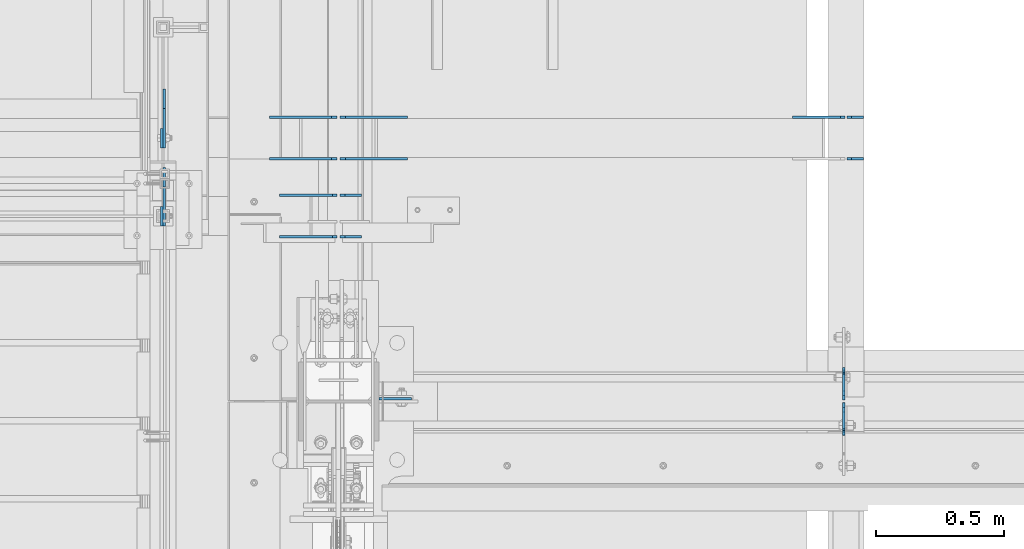
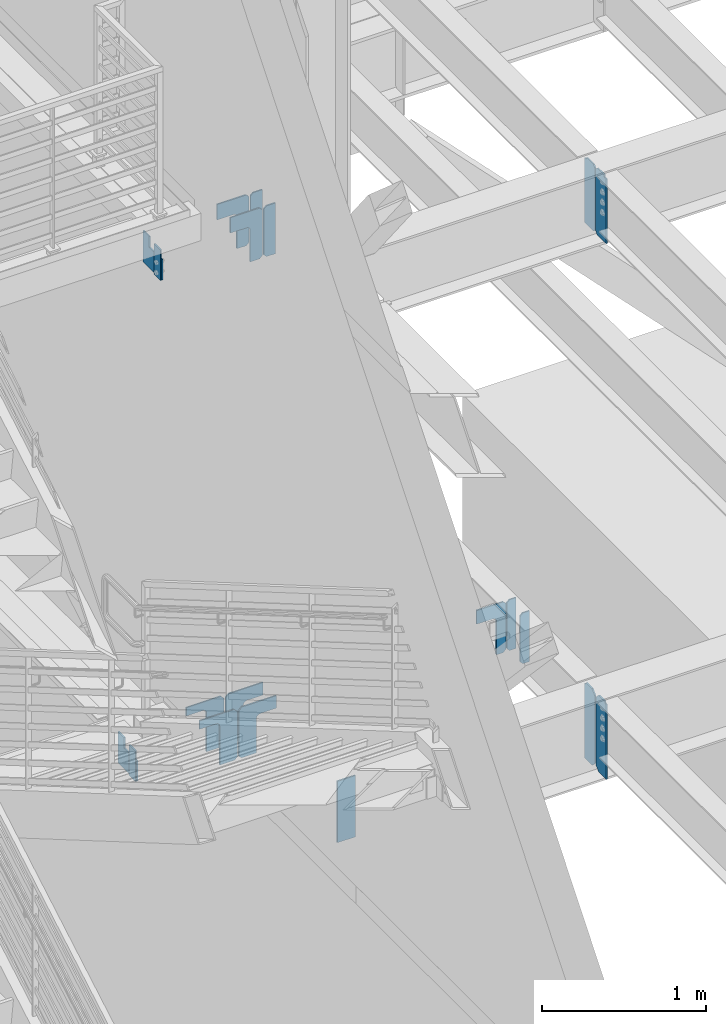
# One storey, part 1060 of 1179: 20 plates, 14 elements without a shape of their own.
"""IFC2X3 building model written with IfcOpenShell, lengths in millimetres."""

from ifc_helpers import new_model, si_unit, frame, origin_with_axes, place, context, subcontext, project, spatial, faceted_brep, material, type_object, element, aggregate, save


model = new_model("IFC2X3")

# Units and contexts
model_context = context("Model", 3, precision=1e-05, world=origin_with_axes())
body_context = subcontext(model_context, "Body", "Model", "MODEL_VIEW")
ifc_project = project(units=[si_unit("LENGTHUNIT", "METRE", prefix="MILLI"), si_unit("AREAUNIT", "SQUARE_METRE"), si_unit("VOLUMEUNIT", "CUBIC_METRE"), si_unit("MASSUNIT", "GRAM", prefix="KILO"), si_unit("TIMEUNIT", "SECOND"), si_unit("PLANEANGLEUNIT", "RADIAN"), si_unit("SOLIDANGLEUNIT", "STERADIAN"), si_unit("THERMODYNAMICTEMPERATUREUNIT", "DEGREE_CELSIUS"), si_unit("LUMINOUSINTENSITYUNIT", "LUMEN")], contexts=[model_context])

# Site, building, storey
site_placement = place(None, origin_with_axes())
site = spatial("IfcSite", under=ifc_project, at=site_placement, CompositionType="ELEMENT")
building_placement = place(site_placement, origin_with_axes())
building = spatial("IfcBuilding", under=site, at=building_placement, Name="Undefined", CompositionType="ELEMENT")
storey_placement = place(building_placement, origin_with_axes())
storey = spatial("IfcBuildingStorey", under=building, at=storey_placement, Name="Undefined", CompositionType="ELEMENT", Elevation=0.0)

# Assembly, plates
assembly_1_placement = place(storey_placement, origin_with_axes())
assembly_1 = element("IfcElementAssembly", 1, at=assembly_1_placement, inside=storey, Name="BEAM", AssemblyPlace="NOTDEFINED", PredefinedType="RIGID_FRAME")
ifc_material = material(Name="STEEL/A36")
plate_type_1 = type_object("IfcPlateType", PredefinedType="NOTDEFINED")
plate_1_placement = place(assembly_1_placement, frame((2405.06200008392, 34396.3625, 7497.7625), z_axis=(0.0, 0.0, 1.0), x_axis=(0.0, 1.0, 0.0)))
plate_1 = element("IfcPlate", 2, at=plate_1_placement, type_object=plate_type_1, material=ifc_material, Name="PLATE", context=body_context, shape_type="Brep", body=[
    faceted_brep([(100.012500000004, -4.76250000000073, 498.475), (100.012500000004, -4.76250000000073, 493.712499809265), (100.012500000004, 4.76250000000073, 493.712499809265), (100.012500000004, 4.76250000000073, 498.475), (100.979229922596, -4.76250000000073, 488.852420291219), (100.979229922596, 4.76250000000073, 488.852420291219), (103.732243823069, -4.76250000000073, 484.732243823066), (103.732243823069, 4.76250000000073, 484.732243823066), (107.852420291223, -4.76250000000073, 481.979229922587), (107.852420291223, 4.76250000000073, 481.979229922587), (112.71249980927, -4.76250000000073, 481.0125), (112.71249980927, 4.76250000000073, 481.0125), (127.000007629395, -4.76250000000073, 481.0125), (127.0, 4.76250000000073, 481.0125), (0.0, -4.76250000000073, 479.425006866455), (19.0499992370605, -4.76250000000073, 498.475006103516), (19.0499992370605, 4.76250000000073, 498.475006103516), (0.0, 4.76250000000073, 479.425006866455), (0.0, -4.76250000000073, 19.0499992370605), (0.0, 4.76250000000073, 19.0499992370605), (19.0499992370605, -4.76250000000073, 0.0), (19.0499992370605, 4.76250000000073, 0.0), (127.0, -4.76250000000073, 0.0), (127.0, 4.76250000000073, 0.0)], [[[0, 1, 2, 3]], [[4, 5, 2, 1]], [[6, 7, 5, 4]], [[8, 9, 7, 6]], [[10, 11, 9, 8]], [[12, 13, 11, 10]], [[14, 15, 16, 17]], [[18, 14, 17, 19]], [[20, 18, 19, 21]], [[22, 20, 21, 23]], [[8, 6, 4, 1, 0, 15, 14, 18, 20, 22, 12, 10]], [[16, 15, 0, 3]], [[23, 21, 19, 17, 16, 3, 2, 5, 7, 9, 11, 13]], [[22, 23, 13, 12]]]),
])
plate_2_placement = place(assembly_1_placement, frame((2405.06200008392, 34386.8375, 7497.7625), z_axis=(0.0, 0.0, 1.0), x_axis=(0.0, -1.0, 0.0)))
plate_2 = element("IfcPlate", 3, at=plate_2_placement, type_object=plate_type_1, material=ifc_material, Name="PLATE", context=body_context, shape_type="Brep", body=[
    faceted_brep([(100.012500000004, -4.76250000000073, 498.475), (100.012500000004, -4.76250000000073, 493.712499809265), (100.012500000004, 4.76250000000073, 493.712499809265), (100.012500000004, 4.76250000000073, 498.475), (100.979229922596, -4.76250000000073, 488.852420291219), (100.979229922596, 4.76250000000073, 488.852420291219), (103.732243823069, -4.76250000000073, 484.732243823066), (103.732243823069, 4.76250000000073, 484.732243823066), (107.852420291223, -4.76250000000073, 481.979229922587), (107.852420291223, 4.76250000000073, 481.979229922587), (112.71249980927, -4.76250000000073, 481.0125), (112.71249980927, 4.76250000000073, 481.0125), (127.000007629395, -4.76250000000073, 481.0125), (127.0, 4.76250000000073, 481.0125), (0.0, -4.76250000000073, 479.425006866455), (19.0499992370605, -4.76250000000073, 498.475006103516), (19.0499992370605, 4.76250000000073, 498.475006103516), (0.0, 4.76250000000073, 479.425006866455), (0.0, -4.76250000000073, 19.0499992370605), (0.0, 4.76250000000073, 19.0499992370605), (19.0499992370605, -4.76250000000073, 0.0), (19.0499992370605, 4.76250000000073, 0.0), (127.0, -4.76250000000073, 0.0), (127.0, 4.76250000000073, 0.0)], [[[0, 1, 2, 3]], [[4, 5, 2, 1]], [[6, 7, 5, 4]], [[8, 9, 7, 6]], [[10, 11, 9, 8]], [[12, 13, 11, 10]], [[14, 15, 16, 17]], [[18, 14, 17, 19]], [[20, 18, 19, 21]], [[22, 20, 21, 23]], [[8, 6, 4, 1, 0, 15, 14, 18, 20, 22, 12, 10]], [[16, 15, 0, 3]], [[23, 21, 19, 17, 16, 3, 2, 5, 7, 9, 11, 13]], [[22, 23, 13, 12]]]),
])
aggregate(assembly_1, [plate_1, plate_2])

# Assembly, plate
assembly_2_placement = place(storey_placement, origin_with_axes())
assembly_2 = element("IfcElementAssembly", 4, at=assembly_2_placement, inside=storey, Name="COLUMN", AssemblyPlace="NOTDEFINED", PredefinedType="RIGID_FRAME")
plate_3_placement = place(assembly_2_placement, frame((588.9625, 34401.91875, 4051.3), z_axis=(1.0, 0.0, 0.0), x_axis=(0.0, 0.0, -1.0)))
plate_3 = element("IfcPlate", 5, at=plate_3_placement, type_object=plate_type_1, material=ifc_material, Name="PLATE", context=body_context, shape_type="Brep", body=[
    faceted_brep([(0.0, -4.76249999999709, 0.0), (0.0, -4.76249999999709, 127.0), (0.0, 4.76249999999709, 127.0), (0.0, 4.76249999999709, 0.0), (457.200012207031, -4.76250000000073, 127.0), (457.200012207031, 4.76250000000073, 127.0), (457.200012207031, -4.76250000000073, 0.0), (457.200012207031, 4.76250000000073, 0.0)], [[[0, 1, 2, 3]], [[1, 4, 5, 2]], [[4, 6, 7, 5]], [[6, 0, 3, 7]], [[5, 7, 3, 2]], [[6, 4, 1, 0]]]),
])
aggregate(assembly_2, [plate_3])

# Assembly, plates
assembly_3_placement = place(storey_placement, origin_with_axes())
assembly_3 = element("IfcElementAssembly", 6, at=assembly_3_placement, inside=storey, Name="BEAM", AssemblyPlace="NOTDEFINED", PredefinedType="RIGID_FRAME")
plate_4_placement = place(assembly_3_placement, frame((2405.06173645238, 34386.04375, 3514.725), z_axis=(0.0, 0.0, 1.0), x_axis=(0.0, -1.0, 0.0)))
plate_4 = element("IfcPlate", 7, at=plate_4_placement, type_object=plate_type_1, material=ifc_material, Name="PLATE", context=body_context, shape_type="Brep", body=[
    faceted_brep([(108.743750000001, -4.76250000000073, 571.5), (108.743750000001, -4.76250000000073, 568.324999809266), (108.743750000001, 4.76250000000073, 568.324999809266), (108.743750000001, 4.76250000000073, 571.5), (109.710479922593, -4.76250000000073, 563.46492029122), (109.710479922593, 4.76250000000073, 563.46492029122), (112.463493823067, -4.76250000000073, 559.344743823066), (112.463493823067, 4.76250000000073, 559.344743823066), (116.58367029122, -4.76250000000073, 556.591729922588), (116.58367029122, 4.76250000000073, 556.591729922588), (121.443749809267, -4.76250000000073, 555.625), (121.443749809267, 4.76250000000073, 555.625), (127.000004116075, -4.76250000000073, 555.625), (127.000004116075, 4.76250000000073, 555.625), (0.0, -4.76250000000073, 536.575000762939), (34.9249992370605, -4.76250000000073, 571.5), (34.9249992370605, 4.76250000000073, 571.5), (0.0, 4.76250000000073, 536.575000762939), (0.0, -4.76250000000073, 34.9249999999993), (0.0, 4.76250000000073, 34.9249999999993), (34.9249992370715, -4.76249999996799, 0.0), (34.9249992370678, 4.76250000003347, 0.0), (127.0, -4.76250000000073, 0.0), (127.0, 4.76250000000073, 0.0)], [[[0, 1, 2, 3]], [[4, 5, 2, 1]], [[6, 7, 5, 4]], [[8, 9, 7, 6]], [[10, 11, 9, 8]], [[12, 13, 11, 10]], [[14, 15, 16, 17]], [[18, 14, 17, 19]], [[20, 18, 19, 21]], [[22, 20, 21, 23]], [[8, 6, 4, 1, 0, 15, 14, 18, 20, 22, 12, 10]], [[16, 15, 0, 3]], [[23, 21, 19, 17, 16, 3, 2, 5, 7, 9, 11, 13]], [[22, 23, 13, 12]]]),
])
plate_5_placement = place(assembly_3_placement, frame((2405.06176856843, 34397.156250119, 3514.725), z_axis=(0.0, 0.0, 1.0), x_axis=(0.0, 1.0, 0.0)))
plate_5 = element("IfcPlate", 8, at=plate_5_placement, type_object=plate_type_1, material=ifc_material, Name="PLATE", context=body_context, shape_type="Brep", body=[
    faceted_brep([(108.743750000001, -4.76250000000073, 571.5), (108.743750000001, -4.76250000000073, 568.324999809266), (108.743750000001, 4.76250000000073, 568.324999809266), (108.743750000001, 4.76250000000073, 571.5), (109.710479922593, -4.76250000000073, 563.46492029122), (109.710479922593, 4.76250000000073, 563.46492029122), (112.463493823067, -4.76250000000073, 559.344743823066), (112.463493823067, 4.76250000000073, 559.344743823066), (116.58367029122, -4.76250000000073, 556.591729922588), (116.58367029122, 4.76250000000073, 556.591729922588), (121.443749809267, -4.76250000000073, 555.625), (121.443749809267, 4.76250000000073, 555.625), (127.000004116075, -4.76250000000073, 555.625), (127.000004116075, 4.76250000000073, 555.625), (0.0, -4.76250000000073, 536.575000762939), (34.9249992370605, -4.76250000000073, 571.5), (34.9249992370605, 4.76250000000073, 571.5), (0.0, 4.76250000000073, 536.575000762939), (0.0, -4.76250000000073, 34.9249999999993), (0.0, 4.76250000000073, 34.9249999999993), (34.9249992370715, -4.76249999996799, 0.0), (34.9249992370678, 4.76250000003347, 0.0), (127.0, -4.76250000000073, 0.0), (127.0, 4.76250000000073, 0.0)], [[[0, 1, 2, 3]], [[4, 5, 2, 1]], [[6, 7, 5, 4]], [[8, 9, 7, 6]], [[10, 11, 9, 8]], [[12, 13, 11, 10]], [[14, 15, 16, 17]], [[18, 14, 17, 19]], [[20, 18, 19, 21]], [[22, 20, 21, 23]], [[8, 6, 4, 1, 0, 15, 14, 18, 20, 22, 12, 10]], [[16, 15, 0, 3]], [[23, 21, 19, 17, 16, 3, 2, 5, 7, 9, 11, 13]], [[22, 23, 13, 12]]]),
])
aggregate(assembly_3, [plate_4, plate_5])

# Assembly, plate
assembly_4_placement = place(storey_placement, origin_with_axes())
assembly_4 = element("IfcElementAssembly", 9, at=assembly_4_placement, inside=storey, Name="BEAM", AssemblyPlace="NOTDEFINED", PredefinedType="RIGID_FRAME")
plate_type_2 = type_object("IfcPlateType", PredefinedType="NOTDEFINED")
plate_6_placement = place(assembly_4_placement, frame((-249.237504637913, 35534.5998361718, 3981.45000000022), z_axis=(0.0, 0.0, -1.0), x_axis=(0.0, 1.0, 0.0)))
plate_6 = element("IfcPlate", 10, at=plate_6_placement, type_object=plate_type_2, material=ifc_material, Name="PLATE", context=body_context, shape_type="Brep", body=[
    faceted_brep([(0.0, -4.76249999999709, 0.0), (0.0, -4.76249999999999, 79.375000001397), (0.0, 4.76249999999999, 79.375000001397), (0.0, 4.76249999999709, 0.0), (-152.39983616901, -4.76249999999999, 79.375000001397), (-152.39983616901, 4.76249999999999, 79.375000001397), (-152.39983616901, -4.76249999999999, 231.775000001398), (-152.39983616901, 4.76249999999999, 231.775000001398), (76.2000000000044, -4.76249999999999, 231.775000001398), (76.2000000000044, 4.76249999999999, 231.775000001398), (76.1999999999971, -4.76249999999999, 0.0), (76.1999999999971, 4.76249999999999, 0.0)], [[[0, 1, 2, 3]], [[1, 4, 5, 2]], [[4, 6, 7, 5]], [[6, 8, 9, 7]], [[8, 10, 11, 9]], [[10, 0, 3, 11]], [[5, 7, 9, 11, 3, 2]], [[10, 8, 6, 4, 1, 0]]]),
])
aggregate(assembly_4, [plate_6])

assembly_5_placement = place(storey_placement, origin_with_axes())
assembly_5 = element("IfcElementAssembly", 11, at=assembly_5_placement, inside=storey, Name="BEAM", AssemblyPlace="NOTDEFINED", PredefinedType="RIGID_FRAME")
plate_7_placement = place(assembly_5_placement, frame((-249.237504637913, 35229.799836169, 7893.05), z_axis=(0.0, 0.0, -1.0), x_axis=(0.0, 1.0, 0.0)))
plate_7 = element("IfcPlate", 12, at=plate_7_placement, type_object=plate_type_2, material=ifc_material, Name="PLATE", context=body_context, shape_type="Brep", body=[
    faceted_brep([(0.0, -4.76249999999709, 0.0), (0.0, -4.76249999999999, 79.375000001397), (0.0, 4.76249999999999, 79.375000001397), (0.0, 4.76249999999709, 0.0), (-152.39983616901, -4.76249999999999, 79.375000001397), (-152.39983616901, 4.76249999999999, 79.375000001397), (-152.39983616901, -4.76249999999999, 231.775000001398), (-152.39983616901, 4.76249999999999, 231.775000001398), (76.2000000000044, -4.76249999999999, 231.775000001398), (76.2000000000044, 4.76249999999999, 231.775000001398), (76.1999999999971, -4.76249999999999, 0.0), (76.1999999999971, 4.76249999999999, 0.0)], [[[0, 1, 2, 3]], [[1, 4, 5, 2]], [[4, 6, 7, 5]], [[6, 8, 9, 7]], [[8, 10, 11, 9]], [[10, 0, 3, 11]], [[5, 7, 9, 11, 3, 2]], [[10, 8, 6, 4, 1, 0]]]),
])
aggregate(assembly_5, [plate_7])

assembly_6_placement = place(storey_placement, origin_with_axes())
assembly_6 = element("IfcElementAssembly", 13, at=assembly_6_placement, inside=storey, Name="BEAM", AssemblyPlace="NOTDEFINED", PredefinedType="RIGID_FRAME")
plate_type_3 = type_object("IfcPlateType", PredefinedType="NOTDEFINED")
plate_8_placement = place(assembly_6_placement, frame((-258.762504637913, 35382.2000000027, 3978.27499999882), z_axis=(0.0, 0.0, -1.0), x_axis=(0.0, 1.0, 0.0)))
plate_8 = element("IfcPlate", 14, at=plate_8_placement, type_object=plate_type_3, material=ifc_material, Name="PLATE", context=body_context, shape_type="Brep", body=[
    faceted_brep([(0.0, -4.76249999999709, 0.0), (0.0, -4.76249999999999, 228.6), (0.0, 4.76249999999999, 228.6), (0.0, 4.76249999999709, 0.0), (76.1999999999971, -4.76249999999999, 228.6), (76.1999999999971, 4.76249999999999, 228.6), (76.1999999999971, -4.76249999999999, 0.0), (76.1999999999971, 4.76249999999999, 0.0)], [[[0, 1, 2, 3]], [[1, 4, 5, 2]], [[4, 6, 7, 5]], [[6, 0, 3, 7]], [[5, 7, 3, 2]], [[6, 4, 1, 0]]]),
])
aggregate(assembly_6, [plate_8])

assembly_7_placement = place(storey_placement, origin_with_axes())
assembly_7 = element("IfcElementAssembly", 15, at=assembly_7_placement, inside=storey, Name="BEAM", AssemblyPlace="NOTDEFINED", PredefinedType="RIGID_FRAME")
plate_9_placement = place(assembly_7_placement, frame((-258.762504637913, 35077.4, 7889.8749999986), z_axis=(0.0, 0.0, -1.0), x_axis=(0.0, 1.0, 0.0)))
plate_9 = element("IfcPlate", 16, at=plate_9_placement, type_object=plate_type_3, material=ifc_material, Name="PLATE", context=body_context, shape_type="Brep", body=[
    faceted_brep([(0.0, -4.76249999999709, 0.0), (0.0, -4.76249999999999, 228.6), (0.0, 4.76249999999999, 228.6), (0.0, 4.76249999999709, 0.0), (76.1999999999971, -4.76249999999999, 228.6), (76.1999999999971, 4.76249999999999, 228.6), (76.1999999999971, -4.76249999999999, 0.0), (76.1999999999971, 4.76249999999999, 0.0)], [[[0, 1, 2, 3]], [[1, 4, 5, 2]], [[4, 6, 7, 5]], [[6, 0, 3, 7]], [[5, 7, 3, 2]], [[6, 4, 1, 0]]]),
])
aggregate(assembly_7, [plate_9])

# Assembly, plates
assembly_8_placement = place(storey_placement, origin_with_axes())
assembly_8 = element("IfcElementAssembly", 17, at=assembly_8_placement, inside=storey, Name="BEAM", AssemblyPlace="NOTDEFINED", PredefinedType="RIGID_FRAME")
plate_type_4 = type_object("IfcPlateType", PredefinedType="NOTDEFINED")
plate_10_placement = place(assembly_8_placement, frame((2481.26232982219, 35339.3374662643, 3711.575), z_axis=(0.0, 0.0, 1.0), x_axis=(-1.0, 0.0, 0.0)))
plate_10 = element("IfcPlate", 18, at=plate_10_placement, type_object=plate_type_4, material=ifc_material, Name="PLATE", context=body_context, shape_type="Brep", body=[
    faceted_brep([(0.0, -4.76249999999709, 0.0), (0.0, -4.76249999999709, 377.825012207031), (0.0, 4.76249999999709, 377.825012207031), (0.0, 4.76249999999709, 0.0), (46.0375022888184, -4.76249999999709, 377.825012207031), (46.0375022888184, 4.76249999999709, 377.825012207031), (65.0875015258789, -4.76249999999709, 358.775012969971), (65.0875015258789, 4.76249999999709, 358.775012969971), (65.0875015258789, -4.76249999999709, 19.0499992370605), (65.0875015258789, 4.76249999999709, 19.0499992370605), (46.0375022888184, -4.76249999999709, 0.0), (46.0375022888184, 4.76249999999709, 0.0)], [[[0, 1, 2, 3]], [[1, 4, 5, 2]], [[4, 6, 7, 5]], [[6, 8, 9, 7]], [[8, 10, 11, 9]], [[10, 0, 3, 11]], [[5, 7, 9, 11, 3, 2]], [[10, 8, 6, 4, 1, 0]]]),
])
plate_11_placement = place(assembly_8_placement, frame((2481.26232577406, 35501.2624662643, 3711.575), z_axis=(0.0, 0.0, 1.0), x_axis=(-1.0, 0.0, 0.0)))
plate_11 = element("IfcPlate", 19, at=plate_11_placement, type_object=plate_type_4, material=ifc_material, Name="PLATE", context=body_context, shape_type="Brep", body=[
    faceted_brep([(0.0, -4.76249999999709, 0.0), (0.0, -4.76249999999709, 377.825012207031), (0.0, 4.76249999999709, 377.825012207031), (0.0, 4.76249999999709, 0.0), (46.0375022888184, -4.76249999999709, 377.825012207031), (46.0375022888184, 4.76249999999709, 377.825012207031), (65.0875015258789, -4.76249999999709, 358.775012969971), (65.0875015258789, 4.76249999999709, 358.775012969971), (65.0875015258789, -4.76249999999709, 19.0499992370605), (65.0875015258789, 4.76249999999709, 19.0499992370605), (46.0375022888184, -4.76249999999709, 0.0), (46.0375022888184, 4.76249999999709, 0.0)], [[[0, 1, 2, 3]], [[1, 4, 5, 2]], [[4, 6, 7, 5]], [[6, 8, 9, 7]], [[8, 10, 11, 9]], [[10, 0, 3, 11]], [[5, 7, 9, 11, 3, 2]], [[10, 8, 6, 4, 1, 0]]]),
])
aggregate(assembly_8, [plate_10, plate_11])

# Assembly, plate
assembly_9_placement = place(storey_placement, origin_with_axes())
assembly_9 = element("IfcElementAssembly", 20, at=assembly_9_placement, inside=storey, Name="BEAM", AssemblyPlace="NOTDEFINED", PredefinedType="RIGID_FRAME")
plate_type_5 = type_object("IfcPlateType", PredefinedType="NOTDEFINED")
plate_12_placement = place(assembly_9_placement, frame((426.291860782879, 35034.5375199548, 7994.65), z_axis=(-1.0, 0.0, 0.0), x_axis=(0.0, 0.0, -1.0)))
plate_12 = element("IfcPlate", 21, at=plate_12_placement, type_object=plate_type_5, material=ifc_material, Name="PLATE", context=body_context, shape_type="Brep", body=[
    faceted_brep([(0.0, -4.76250000000073, 19.0499992370605), (5.15311512572225e-07, -4.76250000051368, 224.679358085698), (5.15311512572225e-07, 4.7624999994805, 224.679358085698), (0.0, 4.76250000000073, 19.0499992370605), (114.300000000001, -4.76249999952415, 224.679310452431), (114.300000000001, 4.7625000004773, 224.679310452431), (114.300000000001, -4.76249999977153, 110.331249618541), (114.300000000001, 4.76250000022992, 110.331249618541), (116.233459845177, -4.76249999979336, 100.61109058245), (116.233459845177, 4.76250000020082, 100.61109058245), (121.739487646133, -4.76249999981519, 92.3707376461425), (121.739487646133, 4.76250000018626, 92.3707376461423), (129.97984058244, -4.76249999982247, 86.8647098451864), (129.97984058244, 4.76250000017899, 86.8647098451863), (139.699999618531, -4.76249999982974, 84.9312500000107), (139.699999618531, 4.76250000017171, 84.9312500000105), (377.825000000001, -4.76249999982974, 84.9312500000098), (377.825000000001, 4.76250000017171, 84.9312500000096), (377.825000000001, -4.76250000004802, 19.0499992370604), (377.825000000001, 4.76249999995343, 19.0499992370605), (358.77500076294, -4.76249999999709, -5.6843418860808e-14), (358.77500076294, 4.76249999999709, 0.0), (19.0499992370605, -4.76250000000073, 0.0), (19.0499992370605, 4.76250000000073, 0.0)], [[[0, 1, 2, 3]], [[1, 4, 5, 2]], [[4, 6, 7, 5]], [[6, 8, 9, 7]], [[8, 10, 11, 9]], [[10, 12, 13, 11]], [[12, 14, 15, 13]], [[14, 16, 17, 15]], [[16, 18, 19, 17]], [[18, 20, 21, 19]], [[20, 22, 23, 21]], [[22, 0, 3, 23]], [[5, 7, 9, 11, 13, 15, 17, 19, 21, 23, 3, 2]], [[22, 20, 18, 16, 14, 12, 10, 8, 6, 4, 1, 0]]]),
])

assembly_10_placement = place(storey_placement, origin_with_axes())
assembly_10 = element("IfcElementAssembly", 22, at=assembly_10_placement, inside=storey, Name="PLATE", AssemblyPlace="NOTDEFINED", PredefinedType="RIGID_FRAME")
plate_13_placement = place(assembly_10_placement, frame((426.291856734725, 35196.462521345, 7994.65), z_axis=(-1.0, 0.0, 0.0), x_axis=(0.0, 0.0, -1.0)))
plate_13 = element("IfcPlate", 23, at=plate_13_placement, type_object=plate_type_5, material=ifc_material, Name="PLATE", context=body_context, shape_type="Brep", body=[
    faceted_brep([(0.0, -4.76250000000073, 19.0499992370605), (5.15311512572225e-07, -4.76250000051368, 224.679358085698), (5.15311512572225e-07, 4.7624999994805, 224.679358085698), (0.0, 4.76250000000073, 19.0499992370605), (114.300000000001, -4.76249999952415, 224.679310452431), (114.300000000001, 4.7625000004773, 224.679310452431), (114.300000000001, -4.76249999977153, 110.331249618541), (114.300000000001, 4.76250000022992, 110.331249618541), (116.233459845177, -4.76249999979336, 100.61109058245), (116.233459845177, 4.76250000020082, 100.61109058245), (121.739487646133, -4.76249999981519, 92.3707376461425), (121.739487646133, 4.76250000018626, 92.3707376461423), (129.97984058244, -4.76249999982247, 86.8647098451864), (129.97984058244, 4.76250000017899, 86.8647098451863), (139.699999618531, -4.76249999982974, 84.9312500000107), (139.699999618531, 4.76250000017171, 84.9312500000105), (377.825000000001, -4.76249999982974, 84.9312500000098), (377.825000000001, 4.76250000017171, 84.9312500000096), (377.825000000001, -4.76250000004802, 19.0499992370604), (377.825000000001, 4.76249999995343, 19.0499992370605), (358.77500076294, -4.76249999999709, -5.6843418860808e-14), (358.77500076294, 4.76249999999709, 0.0), (19.0499992370605, -4.76250000000073, 0.0), (19.0499992370605, 4.76250000000073, 0.0)], [[[0, 1, 2, 3]], [[1, 4, 5, 2]], [[4, 6, 7, 5]], [[6, 8, 9, 7]], [[8, 10, 11, 9]], [[10, 12, 13, 11]], [[12, 14, 15, 13]], [[14, 16, 17, 15]], [[16, 18, 19, 17]], [[18, 20, 21, 19]], [[20, 22, 23, 21]], [[22, 0, 3, 23]], [[5, 7, 9, 11, 13, 15, 17, 19, 21, 23, 3, 2]], [[22, 20, 18, 16, 14, 12, 10, 8, 6, 4, 1, 0]]]),
])
aggregate(assembly_10, [plate_13])

assembly_11_placement = place(storey_placement, origin_with_axes())
assembly_11 = element("IfcElementAssembly", 24, at=assembly_11_placement, inside=storey, Name="PLATE", AssemblyPlace="NOTDEFINED", PredefinedType="RIGID_FRAME")
plate_type_6 = type_object("IfcPlateType", PredefinedType="NOTDEFINED")
plate_14_placement = place(assembly_11_placement, frame((2409.82471255166, 35501.2624673052, 4089.4), z_axis=(-1.0, 0.0, 0.0), x_axis=(0.0, 0.0, -1.0)))
plate_14 = element("IfcPlate", 25, at=plate_14_placement, type_object=plate_type_6, material=ifc_material, Name="PLATE", context=body_context, shape_type="Brep", body=[
    faceted_brep([(0.0, -4.76250000000073, 19.0499992370605), (-8.85103781911312e-06, -4.76249999937863, 206.374999999996), (-8.85103781911312e-06, 4.76250000062282, 206.374999999998), (0.0, 4.76250000000073, 19.0499992370605), (101.599991149047, -4.76249999937863, 206.374988153153), (101.599991149047, 4.76250000062282, 206.374988153154), (101.6, -4.76249999970605, 92.0266613006611), (101.6, 4.7625000002954, 92.0266613006606), (103.533459845175, -4.76249999973516, 82.3065022645701), (103.533459845175, 4.7625000002663, 82.3065022645692), (109.039487646132, -4.76249999976426, 74.0661493282628), (109.039487646132, 4.7625000002372, 74.0661493282619), (117.279840582439, -4.76249999977881, 68.5601215273068), (117.279840582439, 4.76250000022264, 68.5601215273059), (126.99999961853, -4.76249999978609, 66.6266616821308), (126.99999961853, 4.76250000021537, 66.6266616821304), (377.825, -4.76249999978609, 66.6266616821308), (377.825, 4.76250000021537, 66.6266616821304), (377.825000000001, -4.76250000004802, 19.0499992370604), (377.825000000001, 4.76249999995343, 19.0499992370605), (358.77500076294, -4.76249999999709, -5.6843418860808e-14), (358.77500076294, 4.76249999999709, 0.0), (19.0499992370605, -4.76250000000073, 0.0), (19.0499992370605, 4.76250000000073, 0.0)], [[[0, 1, 2, 3]], [[1, 4, 5, 2]], [[4, 6, 7, 5]], [[6, 8, 9, 7]], [[8, 10, 11, 9]], [[10, 12, 13, 11]], [[12, 14, 15, 13]], [[14, 16, 17, 15]], [[16, 18, 19, 17]], [[18, 20, 21, 19]], [[20, 22, 23, 21]], [[22, 0, 3, 23]], [[5, 7, 9, 11, 13, 15, 17, 19, 21, 23, 3, 2]], [[22, 20, 18, 16, 14, 12, 10, 8, 6, 4, 1, 0]]]),
])
aggregate(assembly_11, [plate_14])

# Plate
plate_type_7 = type_object("IfcPlateType", PredefinedType="NOTDEFINED")
plate_15_placement = place(assembly_9_placement, frame((520.700000000001, 35034.5375157507, 7616.825), z_axis=(0.0, 0.0, 1.0), x_axis=(-1.0, 0.0, 0.0)))
plate_15 = element("IfcPlate", 26, at=plate_15_placement, type_object=plate_type_7, material=ifc_material, Name="PLATE", context=body_context, shape_type="Brep", body=[
    faceted_brep([(0.0, -4.76249999999709, 0.0), (0.0, -4.76249999999709, 377.825012207031), (0.0, 4.76249999999709, 377.825012207031), (0.0, 4.76249999999709, 0.0), (64.2937507629395, -4.76249999999709, 377.825012207031), (64.2937507629395, 4.76249999999709, 377.825012207031), (83.34375, -4.76249999999709, 358.775012969971), (83.34375, 4.76249999999709, 358.775012969971), (83.34375, -4.76249999999709, 19.0499992370605), (83.34375, 4.76249999999709, 19.0499992370605), (64.2937507629395, -4.76249999999709, 0.0), (64.2937507629395, 4.76249999999709, 0.0)], [[[0, 1, 2, 3]], [[1, 4, 5, 2]], [[4, 6, 7, 5]], [[6, 8, 9, 7]], [[8, 10, 11, 9]], [[10, 0, 3, 11]], [[5, 7, 9, 11, 3, 2]], [[10, 8, 6, 4, 1, 0]]]),
])

plate_16_placement = place(assembly_9_placement, frame((520.700000000001, 35196.4625157507, 7616.825), z_axis=(0.0, 0.0, 1.0), x_axis=(-1.0, 0.0, 0.0)))
plate_16 = element("IfcPlate", 27, at=plate_16_placement, type_object=plate_type_7, material=ifc_material, Name="PLATE", context=body_context, shape_type="Brep", body=[
    faceted_brep([(0.0, -4.76249999999709, 0.0), (0.0, -4.76249999999709, 377.825012207031), (0.0, 4.76249999999709, 377.825012207031), (0.0, 4.76249999999709, 0.0), (64.2937507629395, -4.76249999999709, 377.825012207031), (64.2937507629395, 4.76249999999709, 377.825012207031), (83.34375, -4.76249999999709, 358.775012969971), (83.34375, 4.76249999999709, 358.775012969971), (83.34375, -4.76249999999709, 19.0499992370605), (83.34375, 4.76249999999709, 19.0499992370605), (64.2937507629395, -4.76249999999709, 0.0), (64.2937507629395, 4.76249999999709, 0.0)], [[[0, 1, 2, 3]], [[1, 4, 5, 2]], [[4, 6, 7, 5]], [[6, 8, 9, 7]], [[8, 10, 11, 9]], [[10, 0, 3, 11]], [[5, 7, 9, 11, 3, 2]], [[10, 8, 6, 4, 1, 0]]]),
])

aggregate(assembly_9, [plate_15, plate_16, plate_12])

# Assembly, plate
assembly_12_placement = place(storey_placement, origin_with_axes())
assembly_12 = element("IfcElementAssembly", 28, at=assembly_12_placement, inside=storey, Name="BEAM", AssemblyPlace="NOTDEFINED", PredefinedType="RIGID_FRAME")
plate_type_8 = type_object("IfcPlateType", PredefinedType="NOTDEFINED")
plate_17_placement = place(assembly_12_placement, frame((426.291860782883, 35339.3375042069, 4081.4625), z_axis=(-1.0, 0.0, 0.0), x_axis=(0.0, 0.0, -1.0)))
plate_17 = element("IfcPlate", 29, at=plate_17_placement, type_object=plate_type_8, material=ifc_material, Name="PLATE", context=body_context, shape_type="Brep", body=[
    faceted_brep([(0.0, -4.76250000000073, 22.2250003814697), (0.0, -4.76250000047003, 264.318756103518), (0.0, 4.76249999953143, 264.318756103518), (0.0, 4.76250000000073, 22.2250003814697), (61.9124999999999, -4.76250000047003, 264.318756103518), (61.9124999999999, 4.76249999953143, 264.318756103518), (61.9124999999999, -4.76250000025902, 148.431249618531), (61.9124999999999, 4.76249999973516, 148.431249618531), (63.8459598451755, -4.76250000024447, 138.71109058244), (63.8459598451755, 4.76249999975698, 138.71109058244), (69.3519876461319, -4.76250000022992, 130.470737646133), (69.3519876461319, 4.76249999977153, 130.470737646133), (77.5923405824392, -4.76250000022264, 124.964709845177), (77.5923405824392, 4.76249999977881, 124.964709845177), (87.3124996185302, -4.76250000021537, 123.031250000001), (87.3124996185302, 4.76249999977881, 123.031250000001), (377.825, -4.76250000021537, 123.031250000001), (377.825, 4.76249999977881, 123.031250000001), (377.825000000001, -4.76250000004802, 19.0499992370604), (377.825000000001, 4.76249999995343, 19.0499992370605), (358.77500076294, -4.76249999999709, -5.6843418860808e-14), (358.77500076294, 4.76249999999709, 0.0), (22.2250003814697, -4.76250000000073, 0.0), (22.2250003814697, 4.76250000000073, 0.0)], [[[0, 1, 2, 3]], [[1, 4, 5, 2]], [[4, 6, 7, 5]], [[6, 8, 9, 7]], [[8, 10, 11, 9]], [[10, 12, 13, 11]], [[12, 14, 15, 13]], [[14, 16, 17, 15]], [[16, 18, 19, 17]], [[18, 20, 21, 19]], [[20, 22, 23, 21]], [[22, 0, 3, 23]], [[5, 7, 9, 11, 13, 15, 17, 19, 21, 23, 3, 2]], [[22, 20, 18, 16, 14, 12, 10, 8, 6, 4, 1, 0]]]),
])

assembly_13_placement = place(storey_placement, origin_with_axes())
assembly_13 = element("IfcElementAssembly", 30, at=assembly_13_placement, inside=storey, Name="PLATE", AssemblyPlace="NOTDEFINED", PredefinedType="RIGID_FRAME")
plate_18_placement = place(assembly_13_placement, frame((426.291856734724, 35501.2625055971, 4081.4625), z_axis=(-1.0, 0.0, 0.0), x_axis=(0.0, 0.0, -1.0)))
plate_18 = element("IfcPlate", 31, at=plate_18_placement, type_object=plate_type_8, material=ifc_material, Name="PLATE", context=body_context, shape_type="Brep", body=[
    faceted_brep([(0.0, -4.76250000000073, 22.2250003814697), (0.0, -4.76250000047003, 264.318756103518), (0.0, 4.76249999953143, 264.318756103518), (0.0, 4.76250000000073, 22.2250003814697), (61.9124999999999, -4.76250000047003, 264.318756103518), (61.9124999999999, 4.76249999953143, 264.318756103518), (61.9124999999999, -4.76250000025902, 148.431249618531), (61.9124999999999, 4.76249999973516, 148.431249618531), (63.8459598451755, -4.76250000024447, 138.71109058244), (63.8459598451755, 4.76249999975698, 138.71109058244), (69.3519876461319, -4.76250000022992, 130.470737646133), (69.3519876461319, 4.76249999977153, 130.470737646133), (77.5923405824392, -4.76250000022264, 124.964709845177), (77.5923405824392, 4.76249999977881, 124.964709845177), (87.3124996185302, -4.76250000021537, 123.031250000001), (87.3124996185302, 4.76249999977881, 123.031250000001), (377.825, -4.76250000021537, 123.031250000001), (377.825, 4.76249999977881, 123.031250000001), (377.825000000001, -4.76250000004802, 19.0499992370604), (377.825000000001, 4.76249999995343, 19.0499992370605), (358.77500076294, -4.76249999999709, -5.6843418860808e-14), (358.77500076294, 4.76249999999709, 0.0), (22.2250003814697, -4.76250000000073, 0.0), (22.2250003814697, 4.76250000000073, 0.0)], [[[0, 1, 2, 3]], [[1, 4, 5, 2]], [[4, 6, 7, 5]], [[6, 8, 9, 7]], [[8, 10, 11, 9]], [[10, 12, 13, 11]], [[12, 14, 15, 13]], [[14, 16, 17, 15]], [[16, 18, 19, 17]], [[18, 20, 21, 19]], [[20, 22, 23, 21]], [[22, 0, 3, 23]], [[5, 7, 9, 11, 13, 15, 17, 19, 21, 23, 3, 2]], [[22, 20, 18, 16, 14, 12, 10, 8, 6, 4, 1, 0]]]),
])
aggregate(assembly_13, [plate_18])

assembly_14_placement = place(storey_placement, origin_with_axes())
assembly_14 = element("IfcElementAssembly", 32, at=assembly_14_placement, inside=storey, Name="PLATE", AssemblyPlace="NOTDEFINED", PredefinedType="RIGID_FRAME")
plate_19_placement = place(assembly_14_placement, frame((437.356108916965, 35501.2624946544, 4081.4625), z_axis=(1.0, 0.0, 0.0), x_axis=(0.0, 0.0, -1.0)))
plate_19 = element("IfcPlate", 33, at=plate_19_placement, type_object=plate_type_8, material=ifc_material, Name="PLATE", context=body_context, shape_type="Brep", body=[
    faceted_brep([(0.0, -4.76250000000073, 22.2250003814697), (0.0, -4.76250000047003, 264.318756103518), (0.0, 4.76249999953143, 264.318756103518), (0.0, 4.76250000000073, 22.2250003814697), (93.6624999999999, -4.76249999943684, 264.318756103516), (93.6624999999999, 4.76250000056461, 264.318756103516), (93.6624999999999, -4.76249999967695, 150.01874961853), (93.6624999999999, 4.76250000032451, 150.01874961853), (95.5959598451755, -4.76249999969878, 140.298590582439), (95.5959598451755, 4.76250000030268, 140.298590582439), (101.101987646132, -4.76249999971333, 132.058237646132), (101.101987646132, 4.76250000028085, 132.058237646132), (109.342340582439, -4.76249999972788, 126.552209845176), (109.342340582439, 4.76250000027358, 126.552209845176), (119.06249961853, -4.76249999973516, 124.61875), (119.06249961853, 4.7625000002663, 124.61875), (377.825, -4.76249999973516, 124.61875), (377.825, 4.7625000002663, 124.61875), (377.825000000001, -4.76250000004802, 19.0499992370604), (377.825000000001, 4.76249999995343, 19.0499992370605), (358.77500076294, -4.76249999999709, -5.6843418860808e-14), (358.77500076294, 4.76249999999709, 0.0), (22.2250003814697, -4.76250000000073, 0.0), (22.2250003814697, 4.76250000000073, 0.0)], [[[0, 1, 2, 3]], [[1, 4, 5, 2]], [[4, 6, 7, 5]], [[6, 8, 9, 7]], [[8, 10, 11, 9]], [[10, 12, 13, 11]], [[12, 14, 15, 13]], [[14, 16, 17, 15]], [[16, 18, 19, 17]], [[18, 20, 21, 19]], [[20, 22, 23, 21]], [[22, 0, 3, 23]], [[5, 7, 9, 11, 13, 15, 17, 19, 21, 23, 3, 2]], [[22, 20, 18, 16, 14, 12, 10, 8, 6, 4, 1, 0]]]),
])
aggregate(assembly_14, [plate_19])

# Plate
plate_20_placement = place(assembly_12_placement, frame((437.356112965123, 35339.3374932642, 4081.4625), z_axis=(1.0, 0.0, 0.0), x_axis=(0.0, 0.0, -1.0)))
plate_20 = element("IfcPlate", 34, at=plate_20_placement, type_object=plate_type_8, material=ifc_material, Name="PLATE", context=body_context, shape_type="Brep", body=[
    faceted_brep([(0.0, -4.76250000000073, 22.2250003814697), (0.0, -4.76250000047003, 264.318756103518), (0.0, 4.76249999953143, 264.318756103518), (0.0, 4.76250000000073, 22.2250003814697), (93.6624999999999, -4.76249999943684, 264.318756103516), (93.6624999999999, 4.76250000056461, 264.318756103516), (93.6624999999999, -4.76249999967695, 150.01874961853), (93.6624999999999, 4.76250000032451, 150.01874961853), (95.5959598451755, -4.76249999969878, 140.298590582439), (95.5959598451755, 4.76250000030268, 140.298590582439), (101.101987646132, -4.76249999971333, 132.058237646132), (101.101987646132, 4.76250000028085, 132.058237646132), (109.342340582439, -4.76249999972788, 126.552209845176), (109.342340582439, 4.76250000027358, 126.552209845176), (119.06249961853, -4.76249999973516, 124.61875), (119.06249961853, 4.7625000002663, 124.61875), (377.825, -4.76249999973516, 124.61875), (377.825, 4.7625000002663, 124.61875), (377.825000000001, -4.76250000004802, 19.0499992370604), (377.825000000001, 4.76249999995343, 19.0499992370605), (358.77500076294, -4.76249999999709, -5.6843418860808e-14), (358.77500076294, 4.76249999999709, 0.0), (22.2250003814697, -4.76250000000073, 0.0), (22.2250003814697, 4.76250000000073, 0.0)], [[[0, 1, 2, 3]], [[1, 4, 5, 2]], [[4, 6, 7, 5]], [[6, 8, 9, 7]], [[8, 10, 11, 9]], [[10, 12, 13, 11]], [[12, 14, 15, 13]], [[14, 16, 17, 15]], [[16, 18, 19, 17]], [[18, 20, 21, 19]], [[20, 22, 23, 21]], [[22, 0, 3, 23]], [[5, 7, 9, 11, 13, 15, 17, 19, 21, 23, 3, 2]], [[22, 20, 18, 16, 14, 12, 10, 8, 6, 4, 1, 0]]]),
])

aggregate(assembly_12, [plate_17, plate_20])

save(model, "model.ifc")
